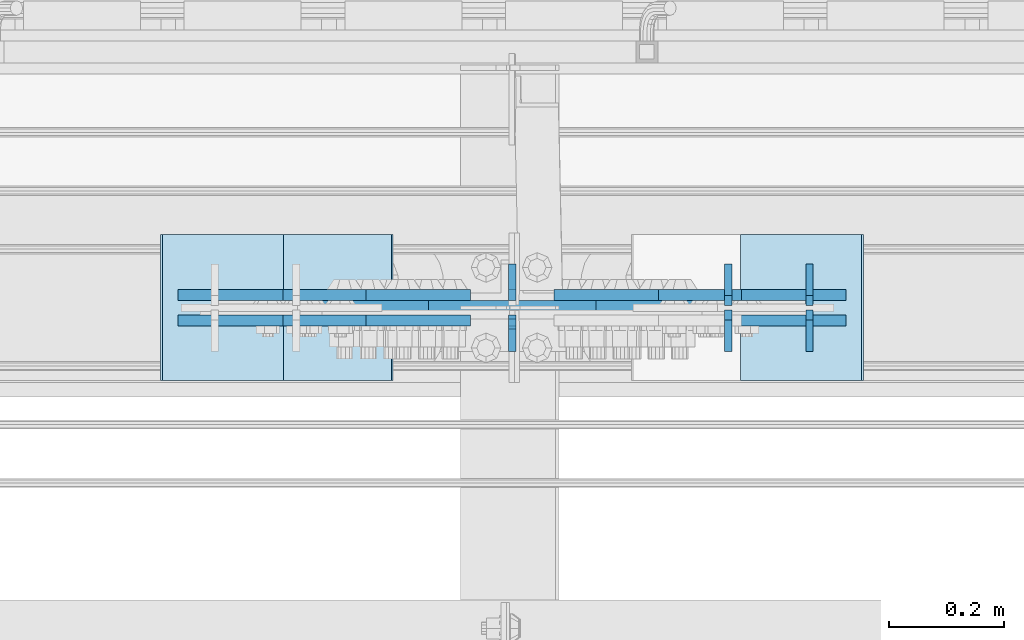
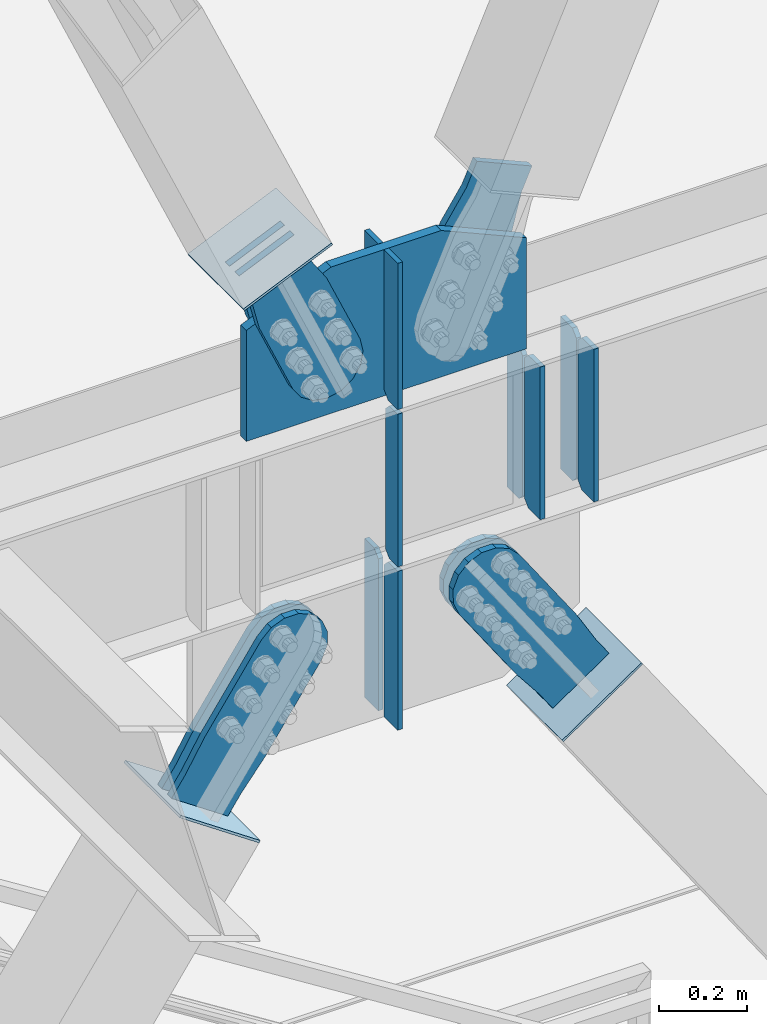
# One storey, part 3159 of 3843: 20 plates, 11 elements without a shape of their own.
"""IFC2X3 building model written with IfcOpenShell, lengths in millimetres."""

from ifc_helpers import new_model, si_unit, frame, origin_with_axes, place, context, subcontext, project, spatial, faceted_brep, material, type_object, element, aggregate, save


model = new_model("IFC2X3")

# Units and contexts
model_context = context("Model", 3, precision=1e-05, world=origin_with_axes())
body_context = subcontext(model_context, "Body", "Model", "MODEL_VIEW")
ifc_project = project(units=[si_unit("LENGTHUNIT", "METRE", prefix="MILLI"), si_unit("AREAUNIT", "SQUARE_METRE"), si_unit("VOLUMEUNIT", "CUBIC_METRE"), si_unit("MASSUNIT", "GRAM", prefix="KILO"), si_unit("TIMEUNIT", "SECOND"), si_unit("PLANEANGLEUNIT", "RADIAN"), si_unit("SOLIDANGLEUNIT", "STERADIAN"), si_unit("THERMODYNAMICTEMPERATUREUNIT", "DEGREE_CELSIUS"), si_unit("LUMINOUSINTENSITYUNIT", "LUMEN")], contexts=[model_context])

# Site, building, storey
site_placement = place(None, origin_with_axes())
site = spatial("IfcSite", under=ifc_project, at=site_placement, CompositionType="ELEMENT")
building_placement = place(site_placement, origin_with_axes())
building = spatial("IfcBuilding", under=site, at=building_placement, Name="Undefined", CompositionType="ELEMENT")
storey_placement = place(building_placement, origin_with_axes())
storey = spatial("IfcBuildingStorey", under=building, at=storey_placement, Name="Undefined", CompositionType="ELEMENT", Elevation=0.0)

# Assembly, plates
assembly_1_placement = place(storey_placement, origin_with_axes())
assembly_1 = element("IfcElementAssembly", 1, at=assembly_1_placement, inside=storey, Name="BEAM", AssemblyPlace="NOTDEFINED", PredefinedType="RIGID_FRAME")
ifc_material_1 = material(Name="STEEL/A572-50")
plate_type_1 = type_object("IfcPlateType", PredefinedType="NOTDEFINED")
plate_1_placement = place(assembly_1_placement, frame((59801.1250006958, 25619.86875, 34372.55), z_axis=(0.0, 1.0, 0.0), x_axis=(0.0, 0.0, 1.0)))
plate_1 = element("IfcPlate", 2, at=plate_1_placement, type_object=plate_type_1, material=ifc_material_1, Name="CB_BEAM", context=body_context, shape_type="Brep", body=[
    faceted_brep([(0.0, -6.34999999999854, 17.4624996185303), (0.0, -6.34999999999854, 72.2312500000007), (0.0, 6.34999999999854, 72.2312500000007), (0.0, 6.34999999999854, 17.4624996185303), (425.449999999997, -6.34999999999854, 72.2312500000007), (425.449999999997, 6.34999999999854, 72.2312500000007), (425.449999999997, -6.34999999999854, 17.4624996185303), (425.449999999997, 6.34999999999854, 17.4624996185303), (407.987500381467, -6.34999999999854, 0.0), (407.987500381467, 6.34999999999854, 0.0), (17.4624996185303, -6.34999999999854, 0.0), (17.4624996185303, 6.34999999999854, 0.0)], [[[0, 1, 2, 3]], [[1, 4, 5, 2]], [[4, 6, 7, 5]], [[6, 8, 9, 7]], [[8, 10, 11, 9]], [[10, 0, 3, 11]], [[5, 7, 9, 11, 3, 2]], [[10, 8, 6, 4, 1, 0]]]),
])
plate_2_placement = place(assembly_1_placement, frame((59801.1250006958, 25611.93125, 34372.55), z_axis=(0.0, -1.0, 0.0), x_axis=(0.0, 0.0, 1.0)))
plate_2 = element("IfcPlate", 3, at=plate_2_placement, type_object=plate_type_1, material=ifc_material_1, Name="CB_BEAM", context=body_context, shape_type="Brep", body=[
    faceted_brep([(0.0, -6.34999999999854, 17.4624996185303), (0.0, -6.34999999999854, 72.2312500000007), (0.0, 6.34999999999854, 72.2312500000007), (0.0, 6.34999999999854, 17.4624996185303), (425.449999999997, -6.34999999999854, 72.2312500000007), (425.449999999997, 6.34999999999854, 72.2312500000007), (425.449999999997, -6.34999999999854, 17.4624996185303), (425.449999999997, 6.34999999999854, 17.4624996185303), (407.987500381467, -6.34999999999854, 0.0), (407.987500381467, 6.34999999999854, 0.0), (17.4624996185303, -6.34999999999854, 0.0), (17.4624996185303, 6.34999999999854, 0.0)], [[[0, 1, 2, 3]], [[1, 4, 5, 2]], [[4, 6, 7, 5]], [[6, 8, 9, 7]], [[8, 10, 11, 9]], [[10, 0, 3, 11]], [[5, 7, 9, 11, 3, 2]], [[10, 8, 6, 4, 1, 0]]]),
])
plate_3_placement = place(assembly_1_placement, frame((59659.8375006958, 25619.86875, 34372.55), z_axis=(0.0, 1.0, 0.0), x_axis=(0.0, 0.0, 1.0)))
plate_3 = element("IfcPlate", 4, at=plate_3_placement, type_object=plate_type_1, material=ifc_material_1, Name="CB_BEAM", context=body_context, shape_type="Brep", body=[
    faceted_brep([(0.0, -6.34999999999854, 17.4624996185303), (0.0, -6.34999999999854, 72.2312500000007), (0.0, 6.34999999999854, 72.2312500000007), (0.0, 6.34999999999854, 17.4624996185303), (425.449999999997, -6.34999999999854, 72.2312500000007), (425.449999999997, 6.34999999999854, 72.2312500000007), (425.449999999997, -6.34999999999854, 17.4624996185303), (425.449999999997, 6.34999999999854, 17.4624996185303), (407.987500381467, -6.34999999999854, 0.0), (407.987500381467, 6.34999999999854, 0.0), (17.4624996185303, -6.34999999999854, 0.0), (17.4624996185303, 6.34999999999854, 0.0)], [[[0, 1, 2, 3]], [[1, 4, 5, 2]], [[4, 6, 7, 5]], [[6, 8, 9, 7]], [[8, 10, 11, 9]], [[10, 0, 3, 11]], [[5, 7, 9, 11, 3, 2]], [[10, 8, 6, 4, 1, 0]]]),
])
plate_4_placement = place(assembly_1_placement, frame((59659.8375006958, 25611.93125, 34372.55), z_axis=(0.0, -1.0, 0.0), x_axis=(0.0, 0.0, 1.0)))
plate_4 = element("IfcPlate", 5, at=plate_4_placement, type_object=plate_type_1, material=ifc_material_1, Name="CB_BEAM", context=body_context, shape_type="Brep", body=[
    faceted_brep([(0.0, -6.34999999999854, 17.4624996185303), (0.0, -6.34999999999854, 72.2312500000007), (0.0, 6.34999999999854, 72.2312500000007), (0.0, 6.34999999999854, 17.4624996185303), (425.449999999997, -6.34999999999854, 72.2312500000007), (425.449999999997, 6.34999999999854, 72.2312500000007), (425.449999999997, -6.34999999999854, 17.4624996185303), (425.449999999997, 6.34999999999854, 17.4624996185303), (407.987500381467, -6.34999999999854, 0.0), (407.987500381467, 6.34999999999854, 0.0), (17.4624996185303, -6.34999999999854, 0.0), (17.4624996185303, 6.34999999999854, 0.0)], [[[0, 1, 2, 3]], [[1, 4, 5, 2]], [[4, 6, 7, 5]], [[6, 8, 9, 7]], [[8, 10, 11, 9]], [[10, 0, 3, 11]], [[5, 7, 9, 11, 3, 2]], [[10, 8, 6, 4, 1, 0]]]),
])

# Assembly, plate
assembly_2_placement = place(storey_placement, origin_with_axes())
assembly_2 = element("IfcElementAssembly", 6, at=assembly_2_placement, inside=storey, AssemblyPlace="NOTDEFINED", PredefinedType="RIGID_FRAME")
ifc_material_2 = material(Name="STEEL/A36")
plate_type_2 = type_object("IfcPlateType", PredefinedType="NOTDEFINED")
plate_5_placement = place(assembly_2_placement, frame((59824.7721123113, 25638.125, 33953.6893092954), z_axis=(-0.825644641353306, 0.0, -0.564190505241423), x_axis=(0.564190505241422, 0.0, -0.825644641353306)))
plate_5 = element("IfcPlate", 7, at=plate_5_placement, type_object=plate_type_2, material=ifc_material_2, context=body_context, shape_type="Brep", body=[
    faceted_brep([(0.0, -9.52500000000146, 0.0), (-101.59999999866, -9.52499999999418, -7.01164927375794), (-101.59999999866, 9.52499999999418, -7.01164927375794), (0.0, 9.52500000000146, 0.0), (-364.729297655074, -9.52499999999418, -7.01164927444188), (-364.729297655074, 9.52499999999418, -7.01164927444188), (-401.787405121293, -9.52499999999418, 0.359666612348519), (-401.787405121293, 9.52499999999418, 0.359666612348519), (-433.203751657995, -9.52499999999418, 21.3513982502482), (-433.203751657995, 9.52499999999418, 21.3513982502482), (-454.195483294687, -9.52499999999418, 52.7677447877504), (-454.195483294687, 9.52499999999418, 52.7677447877504), (-461.566799180051, -9.52499999999418, 89.8258492000314), (-461.566799180051, 9.52499999999418, 89.8258492000314), (-454.195483292249, -9.52499999999418, 126.883956664562), (-454.195483292249, 9.52499999999418, 126.883956664562), (-433.203751654662, -9.52499999999418, 158.300303199998), (-433.203751654662, 9.52499999999418, 158.300303199998), (-401.787405118426, -9.52499999999418, 179.292034836384), (-401.787405118426, 9.52499999999418, 179.292034836384), (-364.729299177612, -9.52499999999418, 186.663350722738), (-364.729299177612, 9.52499999999418, 186.663350722738), (-101.5999999907, -9.52499999999418, 186.663350723451), (-101.5999999907, 9.52499999999418, 186.663350723451), (7.37782102078199e-09, -9.52499999999418, 179.651701450231), (7.37782102078199e-09, 9.52499999999418, 179.651701450231), (69.8500000062704, -9.52499999999418, 179.651701450392), (69.8500000062704, 9.52499999999418, 179.651701450392), (69.8499999979995, -9.52499999999418, -4.00177668780088e-10), (69.8499999979995, 9.52499999999418, -4.00177668780088e-10)], [[[0, 1, 2, 3]], [[1, 4, 5, 2]], [[4, 6, 7, 5]], [[6, 8, 9, 7]], [[8, 10, 11, 9]], [[10, 12, 13, 11]], [[12, 14, 15, 13]], [[14, 16, 17, 15]], [[16, 18, 19, 17]], [[18, 20, 21, 19]], [[20, 22, 23, 21]], [[22, 24, 25, 23]], [[24, 26, 27, 25]], [[26, 28, 29, 27]], [[28, 0, 3, 29]], [[5, 7, 9, 11, 13, 15, 17, 19, 21, 23, 25, 27, 29, 3, 2]], [[28, 26, 24, 22, 20, 18, 16, 14, 12, 10, 8, 6, 4, 1, 0]]]),
])
aggregate(assembly_2, [plate_5])

assembly_3_placement = place(storey_placement, origin_with_axes())
assembly_3 = element("IfcElementAssembly", 8, at=assembly_3_placement, inside=storey, AssemblyPlace="NOTDEFINED", PredefinedType="RIGID_FRAME")
plate_6_placement = place(assembly_3_placement, frame((59824.7721123113, 25593.675, 33953.6893092954), z_axis=(-0.825644641353306, 0.0, -0.564190505241423), x_axis=(0.564190505241422, 0.0, -0.825644641353306)))
plate_6 = element("IfcPlate", 9, at=plate_6_placement, type_object=plate_type_2, material=ifc_material_2, context=body_context, shape_type="Brep", body=[
    faceted_brep([(0.0, -9.52500000000146, 0.0), (-101.59999999866, -9.52499999999418, -7.01164927375794), (-101.59999999866, 9.52499999999418, -7.01164927375794), (0.0, 9.52500000000146, 0.0), (-364.729297655074, -9.52499999999418, -7.01164927444188), (-364.729297655074, 9.52499999999418, -7.01164927444188), (-401.787405121293, -9.52499999999418, 0.359666612348519), (-401.787405121293, 9.52499999999418, 0.359666612348519), (-433.203751657995, -9.52499999999418, 21.3513982502482), (-433.203751657995, 9.52499999999418, 21.3513982502482), (-454.195483294687, -9.52499999999418, 52.7677447877504), (-454.195483294687, 9.52499999999418, 52.7677447877504), (-461.566799180051, -9.52499999999418, 89.8258492000314), (-461.566799180051, 9.52499999999418, 89.8258492000314), (-454.195483292249, -9.52499999999418, 126.883956664562), (-454.195483292249, 9.52499999999418, 126.883956664562), (-433.203751654662, -9.52499999999418, 158.300303199998), (-433.203751654662, 9.52499999999418, 158.300303199998), (-401.787405118426, -9.52499999999418, 179.292034836384), (-401.787405118426, 9.52499999999418, 179.292034836384), (-364.729299177612, -9.52499999999418, 186.663350722738), (-364.729299177612, 9.52499999999418, 186.663350722738), (-101.5999999907, -9.52499999999418, 186.663350723451), (-101.5999999907, 9.52499999999418, 186.663350723451), (7.37782102078199e-09, -9.52499999999418, 179.651701450231), (7.37782102078199e-09, 9.52499999999418, 179.651701450231), (69.8500000062704, -9.52499999999418, 179.651701450392), (69.8500000062704, 9.52499999999418, 179.651701450392), (69.8499999979995, -9.52499999999418, -4.00177668780088e-10), (69.8499999979995, 9.52499999999418, -4.00177668780088e-10)], [[[0, 1, 2, 3]], [[1, 4, 5, 2]], [[4, 6, 7, 5]], [[6, 8, 9, 7]], [[8, 10, 11, 9]], [[10, 12, 13, 11]], [[12, 14, 15, 13]], [[14, 16, 17, 15]], [[16, 18, 19, 17]], [[18, 20, 21, 19]], [[20, 22, 23, 21]], [[22, 24, 25, 23]], [[24, 26, 27, 25]], [[26, 28, 29, 27]], [[28, 0, 3, 29]], [[5, 7, 9, 11, 13, 15, 17, 19, 21, 23, 25, 27, 29, 3, 2]], [[28, 26, 24, 22, 20, 18, 16, 14, 12, 10, 8, 6, 4, 1, 0]]]),
])
aggregate(assembly_3, [plate_6])

assembly_4_placement = place(storey_placement, origin_with_axes())
assembly_4 = element("IfcElementAssembly", 10, at=assembly_4_placement, inside=storey, AssemblyPlace="NOTDEFINED", PredefinedType="RIGID_FRAME")
plate_7_placement = place(assembly_4_placement, frame((58852.25519872, 25638.125, 33794.0159391578), z_axis=(-0.825520173434153, 0.0, 0.564372610296821), x_axis=(0.564372610296811, 0.0, 0.825520173434159)))
plate_7 = element("IfcPlate", 11, at=plate_7_placement, type_object=plate_type_2, material=ifc_material_2, context=body_context, shape_type="Brep", body=[
    faceted_brep([(0.0, -9.52500000000146, 0.0), (7.37782102078199e-09, -9.52499999999418, 179.651701450231), (7.37782102078199e-09, 9.52499999999418, 179.651701450231), (0.0, 9.52500000000146, 0.0), (69.8500000062704, -9.52499999999418, 179.651701450392), (69.8500000062704, 9.52499999999418, 179.651701450392), (171.449999998309, -9.52499999999418, 186.663350727089), (171.449999998309, 9.52499999999418, 186.663350727089), (434.579297655291, -9.52499999999418, 186.663350728457), (434.579297655291, 9.52499999999418, 186.663350728457), (471.637405120986, -9.52499999999418, 179.292034842016), (471.637405120986, 9.52499999999418, 179.292034842016), (503.05375165752, -9.52499999999418, 158.300303204887), (503.05375165752, 9.52499999999418, 158.300303204887), (524.045483294532, -9.52499999999418, 126.883956668345), (524.045483294532, 9.52499999999418, 126.883956668345), (531.416799180792, -9.52499999999418, 89.8258522538526), (531.416799180792, 9.52499999999418, 89.8258522538526), (524.045483293885, -9.52499999999418, 52.7677447886235), (524.045483293885, 9.52499999999418, 52.7677447886235), (503.053751656611, -9.52499999999418, 21.3513982523873), (503.053751656611, 9.52499999999418, 21.3513982523873), (471.637405120178, -9.52499999999418, 0.359666615346214), (471.637405120178, 9.52499999999418, 0.359666615346214), (434.579299181831, -9.52499999999418, -7.01164927131322), (434.579299181831, 9.52499999999418, -7.01164927131322), (171.449999996272, -9.52499999999418, -7.01164927269565), (171.449999996272, 9.52499999999418, -7.01164927269565), (69.8499999979995, -9.52499999999418, -4.00177668780088e-10), (69.8499999979995, 9.52499999999418, -4.00177668780088e-10)], [[[0, 1, 2, 3]], [[1, 4, 5, 2]], [[4, 6, 7, 5]], [[6, 8, 9, 7]], [[8, 10, 11, 9]], [[10, 12, 13, 11]], [[12, 14, 15, 13]], [[14, 16, 17, 15]], [[16, 18, 19, 17]], [[18, 20, 21, 19]], [[20, 22, 23, 21]], [[22, 24, 25, 23]], [[24, 26, 27, 25]], [[26, 28, 29, 27]], [[28, 0, 3, 29]], [[5, 7, 9, 11, 13, 15, 17, 19, 21, 23, 25, 27, 29, 3, 2]], [[28, 26, 24, 22, 20, 18, 16, 14, 12, 10, 8, 6, 4, 1, 0]]]),
])
aggregate(assembly_4, [plate_7])

assembly_5_placement = place(storey_placement, origin_with_axes())
assembly_5 = element("IfcElementAssembly", 12, at=assembly_5_placement, inside=storey, AssemblyPlace="NOTDEFINED", PredefinedType="RIGID_FRAME")
plate_8_placement = place(assembly_5_placement, frame((58852.25519872, 25593.675, 33794.0159391578), z_axis=(-0.825520173434153, 0.0, 0.564372610296821), x_axis=(0.564372610296811, 0.0, 0.825520173434159)))
plate_8 = element("IfcPlate", 13, at=plate_8_placement, type_object=plate_type_2, material=ifc_material_2, context=body_context, shape_type="Brep", body=[
    faceted_brep([(0.0, -9.52500000000146, 0.0), (7.37782102078199e-09, -9.52499999999418, 179.651701450231), (7.37782102078199e-09, 9.52499999999418, 179.651701450231), (0.0, 9.52500000000146, 0.0), (69.8500000062704, -9.52499999999418, 179.651701450392), (69.8500000062704, 9.52499999999418, 179.651701450392), (171.449999998309, -9.52499999999418, 186.663350727089), (171.449999998309, 9.52499999999418, 186.663350727089), (434.579297655291, -9.52499999999418, 186.663350728457), (434.579297655291, 9.52499999999418, 186.663350728457), (471.637405120986, -9.52499999999418, 179.292034842016), (471.637405120986, 9.52499999999418, 179.292034842016), (503.05375165752, -9.52499999999418, 158.300303204887), (503.05375165752, 9.52499999999418, 158.300303204887), (524.045483294532, -9.52499999999418, 126.883956668345), (524.045483294532, 9.52499999999418, 126.883956668345), (531.416799180792, -9.52499999999418, 89.8258522538526), (531.416799180792, 9.52499999999418, 89.8258522538526), (524.045483293885, -9.52499999999418, 52.7677447886235), (524.045483293885, 9.52499999999418, 52.7677447886235), (503.053751656611, -9.52499999999418, 21.3513982523873), (503.053751656611, 9.52499999999418, 21.3513982523873), (471.637405120178, -9.52499999999418, 0.359666615346214), (471.637405120178, 9.52499999999418, 0.359666615346214), (434.579299181831, -9.52499999999418, -7.01164927131322), (434.579299181831, 9.52499999999418, -7.01164927131322), (171.449999996272, -9.52499999999418, -7.01164927269565), (171.449999996272, 9.52499999999418, -7.01164927269565), (69.8499999979995, -9.52499999999418, -4.00177668780088e-10), (69.8499999979995, 9.52499999999418, -4.00177668780088e-10)], [[[0, 1, 2, 3]], [[1, 4, 5, 2]], [[4, 6, 7, 5]], [[6, 8, 9, 7]], [[8, 10, 11, 9]], [[10, 12, 13, 11]], [[12, 14, 15, 13]], [[14, 16, 17, 15]], [[16, 18, 19, 17]], [[18, 20, 21, 19]], [[20, 22, 23, 21]], [[22, 24, 25, 23]], [[24, 26, 27, 25]], [[26, 28, 29, 27]], [[28, 0, 3, 29]], [[5, 7, 9, 11, 13, 15, 17, 19, 21, 23, 25, 27, 29, 3, 2]], [[28, 26, 24, 22, 20, 18, 16, 14, 12, 10, 8, 6, 4, 1, 0]]]),
])
aggregate(assembly_5, [plate_8])

assembly_6_placement = place(storey_placement, origin_with_axes())
assembly_6 = element("IfcElementAssembly", 14, at=assembly_6_placement, inside=storey, AssemblyPlace="NOTDEFINED", PredefinedType="RIGID_FRAME")
plate_9_placement = place(assembly_6_placement, frame((59655.0612525665, 25638.125, 35230.3678887065), z_axis=(-0.91516437406824, 0.0, 0.403080846030032), x_axis=(0.403080846030053, 0.0, 0.915164374068231)))
plate_9 = element("IfcPlate", 15, at=plate_9_placement, type_object=plate_type_2, material=ifc_material_2, context=body_context, shape_type="Brep", body=[
    faceted_brep([(0.0, -9.52500000000146, 0.0), (-101.599999999169, -9.52499999999418, -17.6403935107228), (-101.599999999169, 9.52499999999418, -17.6403935107228), (0.0, 9.52500000000146, 0.0), (-320.279297659972, -9.52499999999418, -17.640393512258), (-320.279297659972, 9.52499999999418, -17.640393512258), (-357.3374051259, -9.52499999999418, -10.2690776257878), (-357.3374051259, 9.52499999999418, -10.2690776257878), (-388.753751662653, -9.52499999999418, 10.7226540115298), (-388.753751662653, 9.52499999999418, 10.7226540115298), (-409.745483299826, -9.52499999999418, 42.1390005483918), (-409.745483299826, 9.52499999999418, 42.1390005483918), (-417.116799186137, -9.52499999999418, 79.1971049608474), (-417.116799186137, 9.52499999999418, 79.1971049608474), (-409.745483299252, -9.52499999999418, 116.255212426157), (-409.745483299252, 9.52499999999418, 116.255212426157), (-388.75375166202, -9.52499999999418, 147.671558962465), (-388.75375166202, 9.52499999999418, 147.671558962465), (-357.33740512564, -9.52499999999418, 168.663290599579), (-357.33740512564, 9.52499999999418, 168.663290599579), (-320.279299186061, -9.52499999999418, 176.034606486319), (-320.279299186061, 9.52499999999418, 176.034606486319), (-101.599999997048, -9.52499999999418, 176.034606487883), (-101.599999997048, 9.52499999999418, 176.034606487883), (1.71894498635083e-09, -9.52499999999418, 158.39421297863), (1.71894498635083e-09, 9.52499999999418, 158.39421297863), (69.8500000010408, -9.52499999999418, 158.394212979103), (69.8500000010408, 9.52499999999418, 158.394212979103), (69.8499999979995, -9.52499999999418, -4.00177668780088e-10), (69.8499999979995, 9.52499999999418, -4.00177668780088e-10)], [[[0, 1, 2, 3]], [[1, 4, 5, 2]], [[4, 6, 7, 5]], [[6, 8, 9, 7]], [[8, 10, 11, 9]], [[10, 12, 13, 11]], [[12, 14, 15, 13]], [[14, 16, 17, 15]], [[16, 18, 19, 17]], [[18, 20, 21, 19]], [[20, 22, 23, 21]], [[22, 24, 25, 23]], [[24, 26, 27, 25]], [[26, 28, 29, 27]], [[28, 0, 3, 29]], [[5, 7, 9, 11, 13, 15, 17, 19, 21, 23, 25, 27, 29, 3, 2]], [[28, 26, 24, 22, 20, 18, 16, 14, 12, 10, 8, 6, 4, 1, 0]]]),
])
aggregate(assembly_6, [plate_9])

assembly_7_placement = place(storey_placement, origin_with_axes())
assembly_7 = element("IfcElementAssembly", 16, at=assembly_7_placement, inside=storey, AssemblyPlace="NOTDEFINED", PredefinedType="RIGID_FRAME")
plate_10_placement = place(assembly_7_placement, frame((59030.6305696723, 25638.125, 35358.1715464964), z_axis=(-0.915217968956094, 0.0, -0.402959140980674), x_axis=(0.402959140980677, 0.0, -0.915217968956092)))
plate_10 = element("IfcPlate", 17, at=plate_10_placement, type_object=plate_type_2, material=ifc_material_2, context=body_context, shape_type="Brep", body=[
    faceted_brep([(0.0, -9.52500000000146, 0.0), (1.71894498635083e-09, -9.52499999999418, 158.39421297863), (1.71894498635083e-09, 9.52499999999418, 158.39421297863), (0.0, 9.52500000000146, 0.0), (69.8500000010408, -9.52499999999418, 158.394212979103), (69.8500000010408, 9.52499999999418, 158.394212979103), (171.450000002631, -9.52499999999418, 176.034606488582), (171.450000002631, 9.52499999999418, 176.034606488582), (390.129297671807, -9.52499999999418, 176.034606487716), (390.129297671807, 9.52499999999418, 176.034606487716), (427.187405137312, -9.52499999999418, 168.663290600991), (427.187405137312, 9.52499999999418, 168.663290600991), (458.60375167372, -9.52499999999418, 147.671558963724), (458.60375167372, 9.52499999999418, 147.671558963724), (479.59548331075, -9.52499999999418, 116.255212427161), (479.59548331075, 9.52499999999418, 116.255212427161), (486.966799197198, -9.52499999999418, 79.1971080138683), (486.966799197198, 9.52499999999418, 79.1971080138683), (479.595483310488, -9.52499999999418, 42.1390005483336), (479.595483310488, 9.52499999999418, 42.1390005483336), (458.603751673207, -9.52499999999418, 10.7226540119082), (458.603751673207, 9.52499999999418, 10.7226540119082), (427.18740513661, -9.52499999999418, -10.2690776251402), (427.18740513661, 9.52499999999418, -10.2690776251402), (390.129299195723, -9.52499999999418, -17.6403935115741), (390.129299195723, 9.52499999999418, -17.6403935115741), (171.450000001962, -9.52499999999418, -17.6403935107155), (171.450000001962, 9.52499999999418, -17.6403935107155), (69.8499999979995, -9.52499999999418, -4.00177668780088e-10), (69.8499999979995, 9.52499999999418, -4.00177668780088e-10)], [[[0, 1, 2, 3]], [[1, 4, 5, 2]], [[4, 6, 7, 5]], [[6, 8, 9, 7]], [[8, 10, 11, 9]], [[10, 12, 13, 11]], [[12, 14, 15, 13]], [[14, 16, 17, 15]], [[16, 18, 19, 17]], [[18, 20, 21, 19]], [[20, 22, 23, 21]], [[22, 24, 25, 23]], [[24, 26, 27, 25]], [[26, 28, 29, 27]], [[28, 0, 3, 29]], [[5, 7, 9, 11, 13, 15, 17, 19, 21, 23, 25, 27, 29, 3, 2]], [[28, 26, 24, 22, 20, 18, 16, 14, 12, 10, 8, 6, 4, 1, 0]]]),
])
aggregate(assembly_7, [plate_10])

assembly_8_placement = place(storey_placement, origin_with_axes())
assembly_8 = element("IfcElementAssembly", 18, at=assembly_8_placement, inside=storey, AssemblyPlace="NOTDEFINED", PredefinedType="RIGID_FRAME")
plate_11_placement = place(assembly_8_placement, frame((59030.6305696723, 25593.675, 35358.1715464964), z_axis=(-0.915217968956094, 0.0, -0.402959140980674), x_axis=(0.402959140980677, 0.0, -0.915217968956092)))
plate_11 = element("IfcPlate", 19, at=plate_11_placement, type_object=plate_type_2, material=ifc_material_2, context=body_context, shape_type="Brep", body=[
    faceted_brep([(0.0, -9.52500000000146, 0.0), (1.71894498635083e-09, -9.52499999999418, 158.39421297863), (1.71894498635083e-09, 9.52499999999418, 158.39421297863), (0.0, 9.52500000000146, 0.0), (69.8500000010408, -9.52499999999418, 158.394212979103), (69.8500000010408, 9.52499999999418, 158.394212979103), (171.450000002631, -9.52499999999418, 176.034606488582), (171.450000002631, 9.52499999999418, 176.034606488582), (390.129297671807, -9.52499999999418, 176.034606487716), (390.129297671807, 9.52499999999418, 176.034606487716), (427.187405137312, -9.52499999999418, 168.663290600991), (427.187405137312, 9.52499999999418, 168.663290600991), (458.60375167372, -9.52499999999418, 147.671558963724), (458.60375167372, 9.52499999999418, 147.671558963724), (479.59548331075, -9.52499999999418, 116.255212427161), (479.59548331075, 9.52499999999418, 116.255212427161), (486.966799197198, -9.52499999999418, 79.1971080138683), (486.966799197198, 9.52499999999418, 79.1971080138683), (479.595483310488, -9.52499999999418, 42.1390005483336), (479.595483310488, 9.52499999999418, 42.1390005483336), (458.603751673207, -9.52499999999418, 10.7226540119082), (458.603751673207, 9.52499999999418, 10.7226540119082), (427.18740513661, -9.52499999999418, -10.2690776251402), (427.18740513661, 9.52499999999418, -10.2690776251402), (390.129299195723, -9.52499999999418, -17.6403935115741), (390.129299195723, 9.52499999999418, -17.6403935115741), (171.450000001962, -9.52499999999418, -17.6403935107155), (171.450000001962, 9.52499999999418, -17.6403935107155), (69.8499999979995, -9.52499999999418, -4.00177668780088e-10), (69.8499999979995, 9.52499999999418, -4.00177668780088e-10)], [[[0, 1, 2, 3]], [[1, 4, 5, 2]], [[4, 6, 7, 5]], [[6, 8, 9, 7]], [[8, 10, 11, 9]], [[10, 12, 13, 11]], [[12, 14, 15, 13]], [[14, 16, 17, 15]], [[16, 18, 19, 17]], [[18, 20, 21, 19]], [[20, 22, 23, 21]], [[22, 24, 25, 23]], [[24, 26, 27, 25]], [[26, 28, 29, 27]], [[28, 0, 3, 29]], [[5, 7, 9, 11, 13, 15, 17, 19, 21, 23, 25, 27, 29, 3, 2]], [[28, 26, 24, 22, 20, 18, 16, 14, 12, 10, 8, 6, 4, 1, 0]]]),
])
aggregate(assembly_8, [plate_11])

assembly_9_placement = place(storey_placement, origin_with_axes())
assembly_9 = element("IfcElementAssembly", 20, at=assembly_9_placement, inside=storey, Name="Plate", AssemblyPlace="NOTDEFINED", PredefinedType="RIGID_FRAME")
plate_type_3 = type_object("IfcPlateType", PredefinedType="NOTDEFINED")
plate_12_placement = place(assembly_9_placement, frame((59683.3684126907, 25742.9, 33776.3083667014), z_axis=(0.825644641353306, 0.0, 0.564190505241423), x_axis=(0.0, -1.0, 0.0)))
plate_12 = element("IfcPlate", 21, at=plate_12_placement, type_object=plate_type_3, material=ifc_material_2, Name="Plate", context=body_context, shape_type="Brep", body=[
    faceted_brep([(0.0, -3.17499999999927, 0.0), (0.0, -3.17499999965185, 254.000000005151), (0.0, 3.17500000035216, 254.000000005166), (0.0, 3.17499999999927, 0.0), (254.0, -3.17499999965185, 254.000000005151), (254.0, 3.17500000035216, 254.000000005166), (254.0, -3.17500000000291, 0.0), (254.0, 3.17499999999927, 1.45519152283669e-11)], [[[0, 1, 2, 3]], [[1, 4, 5, 2]], [[4, 6, 7, 5]], [[6, 0, 3, 7]], [[5, 7, 3, 2]], [[6, 4, 1, 0]]]),
])
aggregate(assembly_9, [plate_12])

assembly_10_placement = place(storey_placement, origin_with_axes())
assembly_10 = element("IfcElementAssembly", 22, at=assembly_10_placement, inside=storey, Name="Plate", AssemblyPlace="NOTDEFINED", PredefinedType="RIGID_FRAME")
plate_13_placement = place(assembly_10_placement, frame((58884.7350919269, 25488.9, 33775.6568940436), z_axis=(-0.825520173434153, 0.0, 0.564372610296821), x_axis=(0.0, 1.0, 0.0)))
plate_13 = element("IfcPlate", 23, at=plate_13_placement, type_object=plate_type_3, material=ifc_material_2, Name="Plate", context=body_context, shape_type="Brep", body=[
    faceted_brep([(0.0, -3.17499999999927, 0.0), (0.0, -3.17499999965185, 254.000000005151), (0.0, 3.17500000035216, 254.000000005166), (0.0, 3.17499999999927, 0.0), (254.0, -3.17499999965185, 254.000000005151), (254.0, 3.17500000035216, 254.000000005166), (254.0, -3.17500000000291, 0.0), (254.0, 3.17499999999927, 1.45519152283669e-11)], [[[0, 1, 2, 3]], [[1, 4, 5, 2]], [[4, 6, 7, 5]], [[6, 0, 3, 7]], [[5, 7, 3, 2]], [[6, 4, 1, 0]]]),
])
aggregate(assembly_10, [plate_13])

assembly_11_placement = place(storey_placement, origin_with_axes())
assembly_11 = element("IfcElementAssembly", 24, at=assembly_11_placement, inside=storey, Name="Plate", AssemblyPlace="NOTDEFINED", PredefinedType="RIGID_FRAME")
plate_14_placement = place(assembly_11_placement, frame((58843.1946680405, 25742.9, 35272.1767205833), z_axis=(0.9152179689561, 0.0, 0.402959140980659), x_axis=(0.0, -1.0, 0.0)))
plate_14 = element("IfcPlate", 25, at=plate_14_placement, type_object=plate_type_3, material=ifc_material_2, Name="Plate", context=body_context, shape_type="Brep", body=[
    faceted_brep([(0.0, -3.17499999999927, 0.0), (0.0, -3.17499999965185, 254.000000005151), (0.0, 3.17500000035216, 254.000000005166), (0.0, 3.17499999999927, 0.0), (254.0, -3.17499999965185, 254.000000005151), (254.0, 3.17500000035216, 254.000000005166), (254.0, -3.17500000000291, 0.0), (254.0, 3.17499999999927, 1.45519152283669e-11)], [[[0, 1, 2, 3]], [[1, 4, 5, 2]], [[4, 6, 7, 5]], [[6, 0, 3, 7]], [[5, 7, 3, 2]], [[6, 4, 1, 0]]]),
])
aggregate(assembly_11, [plate_14])

# Plate
plate_type_4 = type_object("IfcPlateType", PredefinedType="NOTDEFINED")
plate_15_placement = place(assembly_1_placement, frame((58915.361342963, 25615.9, 34810.7), z_axis=(1.0, 0.0, 0.0), x_axis=(0.0, 0.0, 1.0)))
plate_15 = element("IfcPlate", 26, at=plate_15_placement, type_object=plate_type_4, material=ifc_material_1, Name="CB", context=body_context, shape_type="Brep", body=[
    faceted_brep([(0.0, -12.6999999999971, 0.0), (0.0, -12.7000000000007, 738.135930431628), (0.0, 12.7000000000007, 738.135930431628), (0.0, 12.6999999999971, 0.0), (309.338430068914, -12.7000000000007, 738.135930431628), (309.338430068914, 12.7000000000007, 738.135930431628), (407.900945719077, -12.7000000000007, 514.357242285165), (407.900945719077, 12.7000000000007, 514.357242285165), (407.900945719077, -12.7000000000007, 375.38240627561), (407.900945719077, 12.7000000000007, 375.38240627561), (407.900945719077, -12.7000000000007, 223.747912960542), (407.900945719077, 12.7000000000007, 223.747912960542), (309.387509727829, -12.7000000000007, 0.0), (309.387509727829, 12.7000000000007, 0.0)], [[[0, 1, 2, 3]], [[1, 4, 5, 2]], [[4, 6, 7, 5]], [[6, 8, 9, 7]], [[8, 10, 11, 9]], [[10, 12, 13, 11]], [[12, 0, 3, 13]], [[5, 7, 9, 11, 13, 3, 2]], [[12, 10, 8, 6, 4, 1, 0]]]),
])

plate_type_5 = type_object("IfcPlateType", PredefinedType="NOTDEFINED")
plate_16_placement = place(assembly_1_placement, frame((59284.3937493042, 25596.05625, 34372.55), z_axis=(0.0, -1.0, 0.0), x_axis=(0.0, 0.0, 1.0)))
plate_16 = element("IfcPlate", 27, at=plate_16_placement, type_object=plate_type_5, material=ifc_material_1, Name="CB_BEAM", context=body_context, shape_type="Brep", body=[
    faceted_brep([(0.0, -6.34999999999854, 17.4624996185303), (0.0, -6.34999999999854, 56.3562500000007), (0.0, 6.34999999999854, 56.3562500000007), (0.0, 6.34999999999854, 17.4624996185303), (425.449999999997, -6.34999999999854, 56.3562500000007), (425.449999999997, 6.34999999999854, 56.3562500000007), (425.449999999997, -6.34999999999854, 17.4624996185303), (425.449999999997, 6.34999999999854, 17.4624996185303), (407.987500381467, -6.34999999999854, 0.0), (407.987500381467, 6.34999999999854, 0.0), (17.4624996185303, -6.34999999999854, 0.0), (17.4624996185303, 6.34999999999854, 0.0)], [[[0, 1, 2, 3]], [[1, 4, 5, 2]], [[4, 6, 7, 5]], [[6, 8, 9, 7]], [[8, 10, 11, 9]], [[10, 0, 3, 11]], [[5, 7, 9, 11, 3, 2]], [[10, 8, 6, 4, 1, 0]]]),
])

plate_type_6 = type_object("IfcPlateType", PredefinedType="NOTDEFINED")
plate_17_placement = place(assembly_1_placement, frame((59284.3937493042, 25628.6, 33917.334375), z_axis=(0.0, 1.0, 0.0), x_axis=(0.0, 0.0, 1.0)))
plate_17 = element("IfcPlate", 28, at=plate_17_placement, type_object=plate_type_6, material=ifc_material_1, Name="CB", context=body_context, shape_type="Brep", body=[
    faceted_brep([(0.0, -6.3499999046162, 0.0), (0.0, -6.34999999999854, 63.5), (0.0, 6.34999999999854, 63.5), (7.27595761418343e-12, 6.3499999046162, 0.0), (442.590874227542, -6.34999999999854, 63.5), (442.590874227542, 6.34999999999854, 63.5), (442.590874227542, -6.34999999999854, 19.0499992370605), (442.590874227542, 6.34999999999854, 19.0499992370605), (423.540874990482, -6.34999999999854, 0.0), (423.540874990482, 6.34999999999854, 0.0)], [[[0, 1, 2, 3]], [[1, 4, 5, 2]], [[4, 6, 7, 5]], [[6, 8, 9, 7]], [[8, 0, 3, 9]], [[5, 7, 9, 3, 2]], [[8, 6, 4, 1, 0]]]),
])

plate_18_placement = place(assembly_1_placement, frame((59284.3937493042, 25603.2, 33917.334375), z_axis=(0.0, -1.0, 0.0), x_axis=(0.0, 0.0, 1.0)))
plate_18 = element("IfcPlate", 29, at=plate_18_placement, type_object=plate_type_6, material=ifc_material_1, Name="CB", context=body_context, shape_type="Brep", body=[
    faceted_brep([(0.0, -6.3499999046162, 0.0), (0.0, -6.34999999999854, 63.5), (0.0, 6.34999999999854, 63.5), (7.27595761418343e-12, 6.3499999046162, 0.0), (442.590874227542, -6.34999999999854, 63.5), (442.590874227542, 6.34999999999854, 63.5), (442.590874227542, -6.34999999999854, 19.0499992370605), (442.590874227542, 6.34999999999854, 19.0499992370605), (423.540874990482, -6.34999999999854, 0.0), (423.540874990482, 6.34999999999854, 0.0)], [[[0, 1, 2, 3]], [[1, 4, 5, 2]], [[4, 6, 7, 5]], [[6, 8, 9, 7]], [[8, 0, 3, 9]], [[5, 7, 9, 3, 2]], [[8, 6, 4, 1, 0]]]),
])

plate_19_placement = place(assembly_1_placement, frame((59284.3937493042, 25628.6, 34810.7), z_axis=(0.0, 1.0, 0.0), x_axis=(0.0, 0.0, 1.0)))
plate_19 = element("IfcPlate", 30, at=plate_19_placement, type_object=plate_type_6, material=ifc_material_1, Name="CB", context=body_context, shape_type="Brep", body=[
    faceted_brep([(0.0, -6.34999999999854, 19.0499992370605), (0.0, -6.34999999999854, 63.5), (0.0, 6.34999999999854, 63.5), (0.0, 6.34999999999854, 19.0499992370605), (407.900945719077, -6.34999999999854, 63.5), (407.900945719077, 6.34999999999854, 63.5), (407.900945719077, -6.34999999999854, 0.0), (407.900945719077, 6.34999999999854, 0.0), (19.0499992370605, -6.34999999999854, 0.0), (19.0499992370605, 6.34999999999854, 0.0)], [[[0, 1, 2, 3]], [[1, 4, 5, 2]], [[4, 6, 7, 5]], [[6, 8, 9, 7]], [[8, 0, 3, 9]], [[5, 7, 9, 3, 2]], [[8, 6, 4, 1, 0]]]),
])

plate_20_placement = place(assembly_1_placement, frame((59284.3937493042, 25603.2, 34810.7), z_axis=(0.0, -1.0, 0.0), x_axis=(0.0, 0.0, 1.0)))
plate_20 = element("IfcPlate", 31, at=plate_20_placement, type_object=plate_type_6, material=ifc_material_1, Name="CB", context=body_context, shape_type="Brep", body=[
    faceted_brep([(0.0, -6.34999999999854, 19.0499992370605), (0.0, -6.34999999999854, 63.5), (0.0, 6.34999999999854, 63.5), (0.0, 6.34999999999854, 19.0499992370605), (407.900945719077, -6.34999999999854, 63.5), (407.900945719077, 6.34999999999854, 63.5), (407.900945719077, -6.34999999999854, 0.0), (407.900945719077, 6.34999999999854, 0.0), (19.0499992370605, -6.34999999999854, 0.0), (19.0499992370605, 6.34999999999854, 0.0)], [[[0, 1, 2, 3]], [[1, 4, 5, 2]], [[4, 6, 7, 5]], [[6, 8, 9, 7]], [[8, 0, 3, 9]], [[5, 7, 9, 3, 2]], [[8, 6, 4, 1, 0]]]),
])

aggregate(assembly_1, [plate_1, plate_2, plate_3, plate_4, plate_16, plate_17, plate_18, plate_19, plate_20, plate_15])

save(model, "model.ifc")
